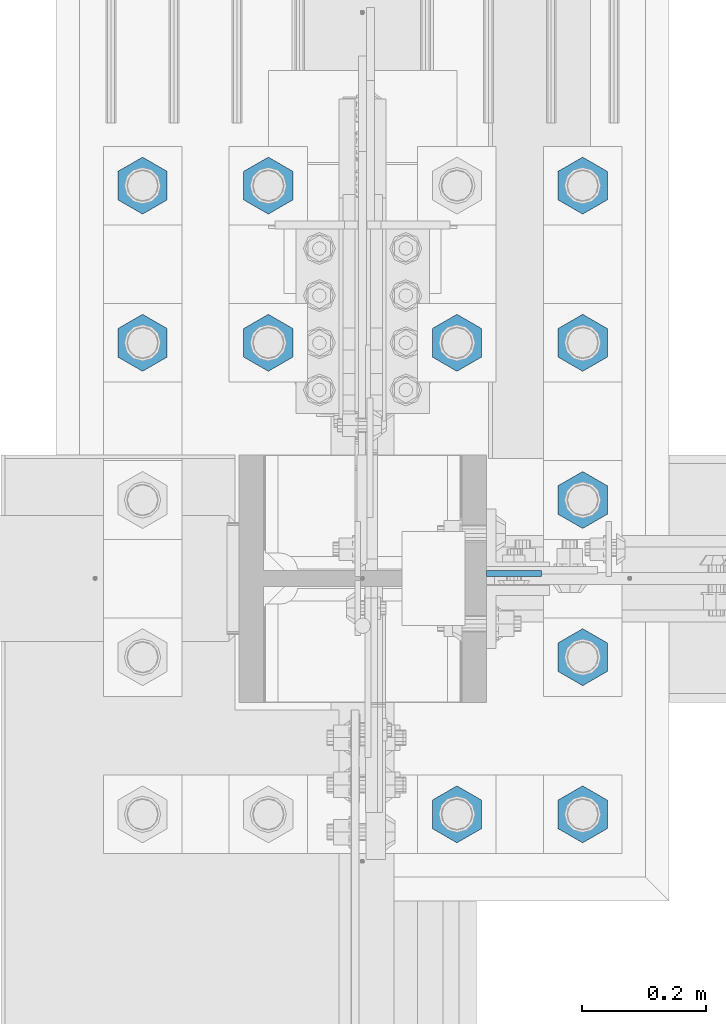
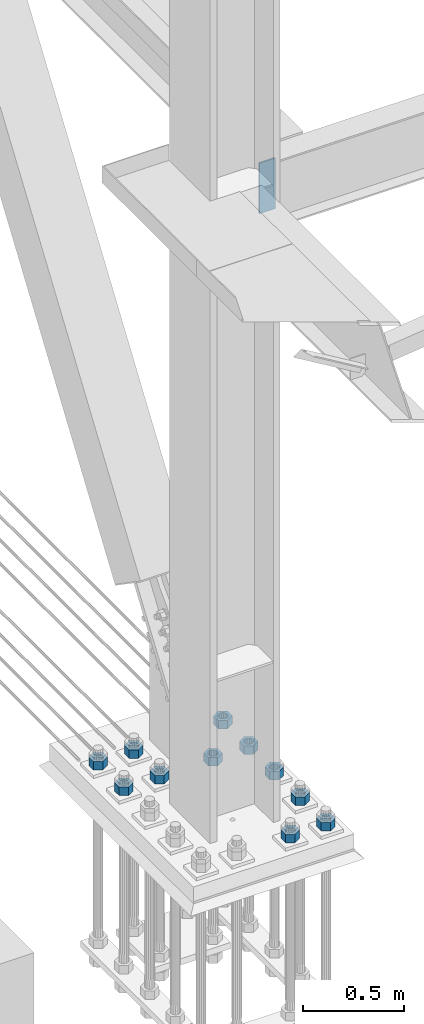
# One storey, part 1520 of 3843: 12 columns, 2 elements without a shape of their own.
"""IFC2X3 building model written with IfcOpenShell, lengths in millimetres."""

from ifc_helpers import new_model, si_unit, frame, origin_with_axes, place, context, subcontext, project, spatial, faceted_brep, material, type_object, element, aggregate, save


model = new_model("IFC2X3")

# Units and contexts
model_context = context("Model", 3, precision=1e-05, world=origin_with_axes())
body_context = subcontext(model_context, "Body", "Model", "MODEL_VIEW")
ifc_project = project(units=[si_unit("LENGTHUNIT", "METRE", prefix="MILLI"), si_unit("AREAUNIT", "SQUARE_METRE"), si_unit("VOLUMEUNIT", "CUBIC_METRE"), si_unit("MASSUNIT", "GRAM", prefix="KILO"), si_unit("TIMEUNIT", "SECOND"), si_unit("PLANEANGLEUNIT", "RADIAN"), si_unit("SOLIDANGLEUNIT", "STERADIAN"), si_unit("THERMODYNAMICTEMPERATUREUNIT", "DEGREE_CELSIUS"), si_unit("LUMINOUSINTENSITYUNIT", "LUMEN")], contexts=[model_context])

# Site, building, storey
site_placement = place(None, origin_with_axes())
site = spatial("IfcSite", under=ifc_project, at=site_placement, CompositionType="ELEMENT")
building_placement = place(site_placement, origin_with_axes())
building = spatial("IfcBuilding", under=site, at=building_placement, Name="Undefined", CompositionType="ELEMENT")
storey_placement = place(building_placement, origin_with_axes())
storey = spatial("IfcBuildingStorey", under=building, at=storey_placement, Name="Undefined", CompositionType="ELEMENT", Elevation=0.0)

# Assembly, column
assembly_1_placement = place(storey_placement, origin_with_axes())
assembly_1 = element("IfcElementAssembly", 1, at=assembly_1_placement, inside=storey, Name="COLUMN", AssemblyPlace="NOTDEFINED", PredefinedType="RIGID_FRAME")
ifc_material = material(Name="STEEL/A572-50")
column_type_1 = type_object("IfcColumnType", PredefinedType="NOTDEFINED")
column_1_placement = place(assembly_1_placement, frame((36820.475, 50566.6375, 33693.0999993376), z_axis=(-1.0, 0.0, 0.0), x_axis=(0.0, 0.0, 1.0)))
column_1 = element("IfcColumn", 2, at=column_1_placement, type_object=column_type_1, material=ifc_material, Name="PLATE", context=body_context, shape_type="Brep", body=[
    faceted_brep([(0.0, 4.76249999999709, -44.4500000000007), (0.0, 4.76249999999709, 44.4500000000007), (304.799999999996, 4.76249999999709, 44.4500000000007), (304.799999999996, 4.76249999999709, -44.4500000000007), (0.0, -4.76249999999709, 44.4500000000007), (304.799999999996, -4.76249999999709, 44.4500000000007), (0.0, -4.76249999999709, -44.4500000000007), (304.799999999996, -4.76249999999709, -44.4500000000007)], [[[0, 1, 2, 3]], [[1, 4, 5, 2]], [[4, 6, 7, 5]], [[6, 0, 3, 7]], [[5, 7, 3, 2]], [[6, 4, 1, 0]]]),
])
aggregate(assembly_1, [column_1])

# Assembly, columns
assembly_2_placement = place(storey_placement, origin_with_axes())
assembly_2 = element("IfcElementAssembly", 3, at=assembly_2_placement, inside=storey, Name="TEMPLATE", AssemblyPlace="NOTDEFINED", PredefinedType="RIGID_FRAME")
column_type_2 = type_object("IfcColumnType", Name="2_HEAVY_HEX_NUT", PredefinedType="NOTDEFINED")
column_2_placement = place(assembly_2_placement, frame((36931.6, 50177.7, 30232.35), z_axis=(1.0, 0.0, 0.0), x_axis=(0.0, 0.0, -1.0)))
column_2 = element("IfcColumn", 4, at=column_2_placement, type_object=column_type_2, material=ifc_material, Name="NUT", ObjectType="2_HEAVY_HEX_NUT", context=body_context, shape_type="Brep", body=[
    faceted_brep([(0.0, -46.0369987487793, 0.0), (0.0, -23.0184993743896, -39.869213104248), (50.7999999999993, -23.0184993743896, -39.869213104248), (50.7999999999993, -46.0369987487793, 0.0), (0.0, 23.0184993743896, -39.869213104248), (50.7999999999993, 23.0184993743896, -39.869213104248), (0.0, 46.0369987487793, 0.0), (50.7999999999993, 46.0369987487793, 0.0), (0.0, 23.0184993743896, 39.869213104248), (50.7999999999993, 23.0184993743896, 39.869213104248), (0.0, -23.0184993743896, 39.869213104248), (50.7999999999993, -23.0184993743896, 39.869213104248), (0.0, 0.0, 26.1940002441406), (0.0, 11.3650617044477, 23.5999013092805), (50.7999999999993, 11.3650617044477, 23.5999013092805), (50.7999999999993, 0.0, 26.1940002441406), (0.0, 20.4791109456419, 16.3316083006721), (50.7999999999993, 20.4791109456419, 16.3316083006721), (0.0, 25.5370200498292, 5.82867859874386), (50.7999999999993, 25.5370200498292, 5.82867859874386), (0.0, 25.5370200498292, -5.82867859874386), (50.7999999999993, 25.5370200498292, -5.82867859874386), (0.0, 20.4791109456419, -16.3316083006721), (50.7999999999993, 20.4791109456419, -16.3316083006721), (0.0, 11.3650617044477, -23.5999013092805), (50.7999999999993, 11.3650617044477, -23.5999013092805), (0.0, 0.0, -26.1940002441406), (50.7999999999993, 0.0, -26.1940002441406), (0.0, -11.3650617044477, -23.5999013092805), (50.7999999999993, -11.3650617044477, -23.5999013092805), (0.0, -20.4791109456419, -16.3316083006721), (50.7999999999993, -20.4791109456419, -16.3316083006721), (0.0, -25.5370200498292, -5.82867859874386), (50.7999999999993, -25.5370200498292, -5.82867859874386), (0.0, -25.5370200498292, 5.82867859874386), (50.7999999999993, -25.5370200498292, 5.82867859874386), (0.0, -20.4791109456419, 16.3316083006721), (50.7999999999993, -20.4791109456419, 16.3316083006721), (0.0, -11.3650617044477, 23.5999013092805), (50.7999999999993, -11.3650617044477, 23.5999013092805)], [[[0, 1, 2, 3]], [[1, 4, 5, 2]], [[4, 6, 7, 5]], [[6, 8, 9, 7]], [[8, 10, 11, 9]], [[10, 0, 3, 11]], [[12, 13, 14, 15]], [[13, 16, 17, 14]], [[16, 18, 19, 17]], [[18, 20, 21, 19]], [[20, 22, 23, 21]], [[22, 24, 25, 23]], [[24, 26, 27, 25]], [[26, 28, 29, 27]], [[28, 30, 31, 29]], [[30, 32, 33, 31]], [[32, 34, 35, 33]], [[34, 36, 37, 35]], [[36, 38, 39, 37]], [[38, 12, 15, 39]], [[5, 7, 9, 11, 3, 2], [17, 19, 21, 23, 25, 27, 29, 31, 33, 35, 37, 39, 15, 14]], [[10, 8, 6, 4, 1, 0], [38, 36, 34, 32, 30, 28, 26, 24, 22, 20, 18, 16, 13, 12]]]),
])
column_3_placement = place(assembly_2_placement, frame((36931.6, 50431.7, 30232.35), z_axis=(1.0, 0.0, 0.0), x_axis=(0.0, 0.0, -1.0)))
column_3 = element("IfcColumn", 5, at=column_3_placement, type_object=column_type_2, material=ifc_material, Name="NUT", ObjectType="2_HEAVY_HEX_NUT", context=body_context, shape_type="Brep", body=[
    faceted_brep([(0.0, -46.0369987487793, 0.0), (0.0, -23.0184993743896, -39.869213104248), (50.7999999999993, -23.0184993743896, -39.869213104248), (50.7999999999993, -46.0369987487793, 0.0), (0.0, 23.0184993743896, -39.869213104248), (50.7999999999993, 23.0184993743896, -39.869213104248), (0.0, 46.0369987487793, 0.0), (50.7999999999993, 46.0369987487793, 0.0), (0.0, 23.0184993743896, 39.869213104248), (50.7999999999993, 23.0184993743896, 39.869213104248), (0.0, -23.0184993743896, 39.869213104248), (50.7999999999993, -23.0184993743896, 39.869213104248), (0.0, 0.0, 26.1940002441406), (0.0, 11.3650617044477, 23.5999013092805), (50.7999999999993, 11.3650617044477, 23.5999013092805), (50.7999999999993, 0.0, 26.1940002441406), (0.0, 20.4791109456419, 16.3316083006721), (50.7999999999993, 20.4791109456419, 16.3316083006721), (0.0, 25.5370200498292, 5.82867859874386), (50.7999999999993, 25.5370200498292, 5.82867859874386), (0.0, 25.5370200498292, -5.82867859874386), (50.7999999999993, 25.5370200498292, -5.82867859874386), (0.0, 20.4791109456419, -16.3316083006721), (50.7999999999993, 20.4791109456419, -16.3316083006721), (0.0, 11.3650617044477, -23.5999013092805), (50.7999999999993, 11.3650617044477, -23.5999013092805), (0.0, 0.0, -26.1940002441406), (50.7999999999993, 0.0, -26.1940002441406), (0.0, -11.3650617044477, -23.5999013092805), (50.7999999999993, -11.3650617044477, -23.5999013092805), (0.0, -20.4791109456419, -16.3316083006721), (50.7999999999993, -20.4791109456419, -16.3316083006721), (0.0, -25.5370200498292, -5.82867859874386), (50.7999999999993, -25.5370200498292, -5.82867859874386), (0.0, -25.5370200498292, 5.82867859874386), (50.7999999999993, -25.5370200498292, 5.82867859874386), (0.0, -20.4791109456419, 16.3316083006721), (50.7999999999993, -20.4791109456419, 16.3316083006721), (0.0, -11.3650617044477, 23.5999013092805), (50.7999999999993, -11.3650617044477, 23.5999013092805)], [[[0, 1, 2, 3]], [[1, 4, 5, 2]], [[4, 6, 7, 5]], [[6, 8, 9, 7]], [[8, 10, 11, 9]], [[10, 0, 3, 11]], [[12, 13, 14, 15]], [[13, 16, 17, 14]], [[16, 18, 19, 17]], [[18, 20, 21, 19]], [[20, 22, 23, 21]], [[22, 24, 25, 23]], [[24, 26, 27, 25]], [[26, 28, 29, 27]], [[28, 30, 31, 29]], [[30, 32, 33, 31]], [[32, 34, 35, 33]], [[34, 36, 37, 35]], [[36, 38, 39, 37]], [[38, 12, 15, 39]], [[5, 7, 9, 11, 3, 2], [17, 19, 21, 23, 25, 27, 29, 31, 33, 35, 37, 39, 15, 14]], [[10, 8, 6, 4, 1, 0], [38, 36, 34, 32, 30, 28, 26, 24, 22, 20, 18, 16, 13, 12]]]),
])
column_4_placement = place(assembly_2_placement, frame((36931.6, 50685.7, 30232.35), z_axis=(1.0, 0.0, 0.0), x_axis=(0.0, 0.0, -1.0)))
column_4 = element("IfcColumn", 6, at=column_4_placement, type_object=column_type_2, material=ifc_material, Name="NUT", ObjectType="2_HEAVY_HEX_NUT", context=body_context, shape_type="Brep", body=[
    faceted_brep([(0.0, -46.0369987487793, 0.0), (0.0, -23.0184993743896, -39.869213104248), (50.7999999999993, -23.0184993743896, -39.869213104248), (50.7999999999993, -46.0369987487793, 0.0), (0.0, 23.0184993743896, -39.869213104248), (50.7999999999993, 23.0184993743896, -39.869213104248), (0.0, 46.0369987487793, 0.0), (50.7999999999993, 46.0369987487793, 0.0), (0.0, 23.0184993743896, 39.869213104248), (50.7999999999993, 23.0184993743896, 39.869213104248), (0.0, -23.0184993743896, 39.869213104248), (50.7999999999993, -23.0184993743896, 39.869213104248), (0.0, 0.0, 26.1940002441406), (0.0, 11.3650617044477, 23.5999013092805), (50.7999999999993, 11.3650617044477, 23.5999013092805), (50.7999999999993, 0.0, 26.1940002441406), (0.0, 20.4791109456419, 16.3316083006721), (50.7999999999993, 20.4791109456419, 16.3316083006721), (0.0, 25.5370200498292, 5.82867859874386), (50.7999999999993, 25.5370200498292, 5.82867859874386), (0.0, 25.5370200498292, -5.82867859874386), (50.7999999999993, 25.5370200498292, -5.82867859874386), (0.0, 20.4791109456419, -16.3316083006721), (50.7999999999993, 20.4791109456419, -16.3316083006721), (0.0, 11.3650617044477, -23.5999013092805), (50.7999999999993, 11.3650617044477, -23.5999013092805), (0.0, 0.0, -26.1940002441406), (50.7999999999993, 0.0, -26.1940002441406), (0.0, -11.3650617044477, -23.5999013092805), (50.7999999999993, -11.3650617044477, -23.5999013092805), (0.0, -20.4791109456419, -16.3316083006721), (50.7999999999993, -20.4791109456419, -16.3316083006721), (0.0, -25.5370200498292, -5.82867859874386), (50.7999999999993, -25.5370200498292, -5.82867859874386), (0.0, -25.5370200498292, 5.82867859874386), (50.7999999999993, -25.5370200498292, 5.82867859874386), (0.0, -20.4791109456419, 16.3316083006721), (50.7999999999993, -20.4791109456419, 16.3316083006721), (0.0, -11.3650617044477, 23.5999013092805), (50.7999999999993, -11.3650617044477, 23.5999013092805)], [[[0, 1, 2, 3]], [[1, 4, 5, 2]], [[4, 6, 7, 5]], [[6, 8, 9, 7]], [[8, 10, 11, 9]], [[10, 0, 3, 11]], [[12, 13, 14, 15]], [[13, 16, 17, 14]], [[16, 18, 19, 17]], [[18, 20, 21, 19]], [[20, 22, 23, 21]], [[22, 24, 25, 23]], [[24, 26, 27, 25]], [[26, 28, 29, 27]], [[28, 30, 31, 29]], [[30, 32, 33, 31]], [[32, 34, 35, 33]], [[34, 36, 37, 35]], [[36, 38, 39, 37]], [[38, 12, 15, 39]], [[5, 7, 9, 11, 3, 2], [17, 19, 21, 23, 25, 27, 29, 31, 33, 35, 37, 39, 15, 14]], [[10, 8, 6, 4, 1, 0], [38, 36, 34, 32, 30, 28, 26, 24, 22, 20, 18, 16, 13, 12]]]),
])
column_5_placement = place(assembly_2_placement, frame((36931.6, 50939.7, 30232.35), z_axis=(-1.0, 0.0, 0.0), x_axis=(0.0, 0.0, -1.0)))
column_5 = element("IfcColumn", 7, at=column_5_placement, type_object=column_type_2, material=ifc_material, Name="NUT", ObjectType="2_HEAVY_HEX_NUT", context=body_context, shape_type="Brep", body=[
    faceted_brep([(0.0, -46.0369987487793, 0.0), (0.0, -23.0184993743896, -39.869213104248), (50.7999999999993, -23.0184993743896, -39.869213104248), (50.7999999999993, -46.0369987487793, 0.0), (0.0, 23.0184993743896, -39.869213104248), (50.7999999999993, 23.0184993743896, -39.869213104248), (0.0, 46.0369987487793, 0.0), (50.7999999999993, 46.0369987487793, 0.0), (0.0, 23.0184993743896, 39.869213104248), (50.7999999999993, 23.0184993743896, 39.869213104248), (0.0, -23.0184993743896, 39.869213104248), (50.7999999999993, -23.0184993743896, 39.869213104248), (0.0, 0.0, 26.1940002441406), (0.0, 11.3650617044477, 23.5999013092805), (50.7999999999993, 11.3650617044477, 23.5999013092805), (50.7999999999993, 0.0, 26.1940002441406), (0.0, 20.4791109456419, 16.3316083006721), (50.7999999999993, 20.4791109456419, 16.3316083006721), (0.0, 25.5370200498292, 5.82867859874386), (50.7999999999993, 25.5370200498292, 5.82867859874386), (0.0, 25.5370200498292, -5.82867859874386), (50.7999999999993, 25.5370200498292, -5.82867859874386), (0.0, 20.4791109456419, -16.3316083006721), (50.7999999999993, 20.4791109456419, -16.3316083006721), (0.0, 11.3650617044477, -23.5999013092805), (50.7999999999993, 11.3650617044477, -23.5999013092805), (0.0, 0.0, -26.1940002441406), (50.7999999999993, 0.0, -26.1940002441406), (0.0, -11.3650617044477, -23.5999013092805), (50.7999999999993, -11.3650617044477, -23.5999013092805), (0.0, -20.4791109456419, -16.3316083006721), (50.7999999999993, -20.4791109456419, -16.3316083006721), (0.0, -25.5370200498292, -5.82867859874386), (50.7999999999993, -25.5370200498292, -5.82867859874386), (0.0, -25.5370200498292, 5.82867859874386), (50.7999999999993, -25.5370200498292, 5.82867859874386), (0.0, -20.4791109456419, 16.3316083006721), (50.7999999999993, -20.4791109456419, 16.3316083006721), (0.0, -11.3650617044477, 23.5999013092805), (50.7999999999993, -11.3650617044477, 23.5999013092805)], [[[0, 1, 2, 3]], [[1, 4, 5, 2]], [[4, 6, 7, 5]], [[6, 8, 9, 7]], [[8, 10, 11, 9]], [[10, 0, 3, 11]], [[12, 13, 14, 15]], [[13, 16, 17, 14]], [[16, 18, 19, 17]], [[18, 20, 21, 19]], [[20, 22, 23, 21]], [[22, 24, 25, 23]], [[24, 26, 27, 25]], [[26, 28, 29, 27]], [[28, 30, 31, 29]], [[30, 32, 33, 31]], [[32, 34, 35, 33]], [[34, 36, 37, 35]], [[36, 38, 39, 37]], [[38, 12, 15, 39]], [[5, 7, 9, 11, 3, 2], [17, 19, 21, 23, 25, 27, 29, 31, 33, 35, 37, 39, 15, 14]], [[10, 8, 6, 4, 1, 0], [38, 36, 34, 32, 30, 28, 26, 24, 22, 20, 18, 16, 13, 12]]]),
])
column_6_placement = place(assembly_2_placement, frame((36931.6, 51193.7, 30232.35), z_axis=(-1.0, 0.0, 0.0), x_axis=(0.0, 0.0, -1.0)))
column_6 = element("IfcColumn", 8, at=column_6_placement, type_object=column_type_2, material=ifc_material, Name="NUT", ObjectType="2_HEAVY_HEX_NUT", context=body_context, shape_type="Brep", body=[
    faceted_brep([(0.0, -46.0369987487793, 0.0), (0.0, -23.0184993743896, -39.869213104248), (50.7999999999993, -23.0184993743896, -39.869213104248), (50.7999999999993, -46.0369987487793, 0.0), (0.0, 23.0184993743896, -39.869213104248), (50.7999999999993, 23.0184993743896, -39.869213104248), (0.0, 46.0369987487793, 0.0), (50.7999999999993, 46.0369987487793, 0.0), (0.0, 23.0184993743896, 39.869213104248), (50.7999999999993, 23.0184993743896, 39.869213104248), (0.0, -23.0184993743896, 39.869213104248), (50.7999999999993, -23.0184993743896, 39.869213104248), (0.0, 0.0, 26.1940002441406), (0.0, 11.3650617044477, 23.5999013092805), (50.7999999999993, 11.3650617044477, 23.5999013092805), (50.7999999999993, 0.0, 26.1940002441406), (0.0, 20.4791109456419, 16.3316083006721), (50.7999999999993, 20.4791109456419, 16.3316083006721), (0.0, 25.5370200498292, 5.82867859874386), (50.7999999999993, 25.5370200498292, 5.82867859874386), (0.0, 25.5370200498292, -5.82867859874386), (50.7999999999993, 25.5370200498292, -5.82867859874386), (0.0, 20.4791109456419, -16.3316083006721), (50.7999999999993, 20.4791109456419, -16.3316083006721), (0.0, 11.3650617044477, -23.5999013092805), (50.7999999999993, 11.3650617044477, -23.5999013092805), (0.0, 0.0, -26.1940002441406), (50.7999999999993, 0.0, -26.1940002441406), (0.0, -11.3650617044477, -23.5999013092805), (50.7999999999993, -11.3650617044477, -23.5999013092805), (0.0, -20.4791109456419, -16.3316083006721), (50.7999999999993, -20.4791109456419, -16.3316083006721), (0.0, -25.5370200498292, -5.82867859874386), (50.7999999999993, -25.5370200498292, -5.82867859874386), (0.0, -25.5370200498292, 5.82867859874386), (50.7999999999993, -25.5370200498292, 5.82867859874386), (0.0, -20.4791109456419, 16.3316083006721), (50.7999999999993, -20.4791109456419, 16.3316083006721), (0.0, -11.3650617044477, 23.5999013092805), (50.7999999999993, -11.3650617044477, 23.5999013092805)], [[[0, 1, 2, 3]], [[1, 4, 5, 2]], [[4, 6, 7, 5]], [[6, 8, 9, 7]], [[8, 10, 11, 9]], [[10, 0, 3, 11]], [[12, 13, 14, 15]], [[13, 16, 17, 14]], [[16, 18, 19, 17]], [[18, 20, 21, 19]], [[20, 22, 23, 21]], [[22, 24, 25, 23]], [[24, 26, 27, 25]], [[26, 28, 29, 27]], [[28, 30, 31, 29]], [[30, 32, 33, 31]], [[32, 34, 35, 33]], [[34, 36, 37, 35]], [[36, 38, 39, 37]], [[38, 12, 15, 39]], [[5, 7, 9, 11, 3, 2], [17, 19, 21, 23, 25, 27, 29, 31, 33, 35, 37, 39, 15, 14]], [[10, 8, 6, 4, 1, 0], [38, 36, 34, 32, 30, 28, 26, 24, 22, 20, 18, 16, 13, 12]]]),
])
column_7_placement = place(assembly_2_placement, frame((36728.4, 50177.7, 30232.35), z_axis=(1.0, 0.0, 0.0), x_axis=(0.0, 0.0, -1.0)))
column_7 = element("IfcColumn", 9, at=column_7_placement, type_object=column_type_2, material=ifc_material, Name="NUT", ObjectType="2_HEAVY_HEX_NUT", context=body_context, shape_type="Brep", body=[
    faceted_brep([(0.0, -46.0369987487793, 0.0), (0.0, -23.0184993743896, -39.869213104248), (50.7999999999993, -23.0184993743896, -39.869213104248), (50.7999999999993, -46.0369987487793, 0.0), (0.0, 23.0184993743896, -39.869213104248), (50.7999999999993, 23.0184993743896, -39.869213104248), (0.0, 46.0369987487793, 0.0), (50.7999999999993, 46.0369987487793, 0.0), (0.0, 23.0184993743896, 39.869213104248), (50.7999999999993, 23.0184993743896, 39.869213104248), (0.0, -23.0184993743896, 39.869213104248), (50.7999999999993, -23.0184993743896, 39.869213104248), (0.0, 0.0, 26.1940002441406), (0.0, 11.3650617044477, 23.5999013092805), (50.7999999999993, 11.3650617044477, 23.5999013092805), (50.7999999999993, 0.0, 26.1940002441406), (0.0, 20.4791109456419, 16.3316083006721), (50.7999999999993, 20.4791109456419, 16.3316083006721), (0.0, 25.5370200498292, 5.82867859874386), (50.7999999999993, 25.5370200498292, 5.82867859874386), (0.0, 25.5370200498292, -5.82867859874386), (50.7999999999993, 25.5370200498292, -5.82867859874386), (0.0, 20.4791109456419, -16.3316083006721), (50.7999999999993, 20.4791109456419, -16.3316083006721), (0.0, 11.3650617044477, -23.5999013092805), (50.7999999999993, 11.3650617044477, -23.5999013092805), (0.0, 0.0, -26.1940002441406), (50.7999999999993, 0.0, -26.1940002441406), (0.0, -11.3650617044477, -23.5999013092805), (50.7999999999993, -11.3650617044477, -23.5999013092805), (0.0, -20.4791109456419, -16.3316083006721), (50.7999999999993, -20.4791109456419, -16.3316083006721), (0.0, -25.5370200498292, -5.82867859874386), (50.7999999999993, -25.5370200498292, -5.82867859874386), (0.0, -25.5370200498292, 5.82867859874386), (50.7999999999993, -25.5370200498292, 5.82867859874386), (0.0, -20.4791109456419, 16.3316083006721), (50.7999999999993, -20.4791109456419, 16.3316083006721), (0.0, -11.3650617044477, 23.5999013092805), (50.7999999999993, -11.3650617044477, 23.5999013092805)], [[[0, 1, 2, 3]], [[1, 4, 5, 2]], [[4, 6, 7, 5]], [[6, 8, 9, 7]], [[8, 10, 11, 9]], [[10, 0, 3, 11]], [[12, 13, 14, 15]], [[13, 16, 17, 14]], [[16, 18, 19, 17]], [[18, 20, 21, 19]], [[20, 22, 23, 21]], [[22, 24, 25, 23]], [[24, 26, 27, 25]], [[26, 28, 29, 27]], [[28, 30, 31, 29]], [[30, 32, 33, 31]], [[32, 34, 35, 33]], [[34, 36, 37, 35]], [[36, 38, 39, 37]], [[38, 12, 15, 39]], [[5, 7, 9, 11, 3, 2], [17, 19, 21, 23, 25, 27, 29, 31, 33, 35, 37, 39, 15, 14]], [[10, 8, 6, 4, 1, 0], [38, 36, 34, 32, 30, 28, 26, 24, 22, 20, 18, 16, 13, 12]]]),
])
column_8_placement = place(assembly_2_placement, frame((36728.4, 50939.7, 30232.35), z_axis=(-1.0, 0.0, 0.0), x_axis=(0.0, 0.0, -1.0)))
column_8 = element("IfcColumn", 10, at=column_8_placement, type_object=column_type_2, material=ifc_material, Name="NUT", ObjectType="2_HEAVY_HEX_NUT", context=body_context, shape_type="Brep", body=[
    faceted_brep([(0.0, -46.0369987487793, 0.0), (0.0, -23.0184993743896, -39.869213104248), (50.7999999999993, -23.0184993743896, -39.869213104248), (50.7999999999993, -46.0369987487793, 0.0), (0.0, 23.0184993743896, -39.869213104248), (50.7999999999993, 23.0184993743896, -39.869213104248), (0.0, 46.0369987487793, 0.0), (50.7999999999993, 46.0369987487793, 0.0), (0.0, 23.0184993743896, 39.869213104248), (50.7999999999993, 23.0184993743896, 39.869213104248), (0.0, -23.0184993743896, 39.869213104248), (50.7999999999993, -23.0184993743896, 39.869213104248), (0.0, 0.0, 26.1940002441406), (0.0, 11.3650617044477, 23.5999013092805), (50.7999999999993, 11.3650617044477, 23.5999013092805), (50.7999999999993, 0.0, 26.1940002441406), (0.0, 20.4791109456419, 16.3316083006721), (50.7999999999993, 20.4791109456419, 16.3316083006721), (0.0, 25.5370200498292, 5.82867859874386), (50.7999999999993, 25.5370200498292, 5.82867859874386), (0.0, 25.5370200498292, -5.82867859874386), (50.7999999999993, 25.5370200498292, -5.82867859874386), (0.0, 20.4791109456419, -16.3316083006721), (50.7999999999993, 20.4791109456419, -16.3316083006721), (0.0, 11.3650617044477, -23.5999013092805), (50.7999999999993, 11.3650617044477, -23.5999013092805), (0.0, 0.0, -26.1940002441406), (50.7999999999993, 0.0, -26.1940002441406), (0.0, -11.3650617044477, -23.5999013092805), (50.7999999999993, -11.3650617044477, -23.5999013092805), (0.0, -20.4791109456419, -16.3316083006721), (50.7999999999993, -20.4791109456419, -16.3316083006721), (0.0, -25.5370200498292, -5.82867859874386), (50.7999999999993, -25.5370200498292, -5.82867859874386), (0.0, -25.5370200498292, 5.82867859874386), (50.7999999999993, -25.5370200498292, 5.82867859874386), (0.0, -20.4791109456419, 16.3316083006721), (50.7999999999993, -20.4791109456419, 16.3316083006721), (0.0, -11.3650617044477, 23.5999013092805), (50.7999999999993, -11.3650617044477, 23.5999013092805)], [[[0, 1, 2, 3]], [[1, 4, 5, 2]], [[4, 6, 7, 5]], [[6, 8, 9, 7]], [[8, 10, 11, 9]], [[10, 0, 3, 11]], [[12, 13, 14, 15]], [[13, 16, 17, 14]], [[16, 18, 19, 17]], [[18, 20, 21, 19]], [[20, 22, 23, 21]], [[22, 24, 25, 23]], [[24, 26, 27, 25]], [[26, 28, 29, 27]], [[28, 30, 31, 29]], [[30, 32, 33, 31]], [[32, 34, 35, 33]], [[34, 36, 37, 35]], [[36, 38, 39, 37]], [[38, 12, 15, 39]], [[5, 7, 9, 11, 3, 2], [17, 19, 21, 23, 25, 27, 29, 31, 33, 35, 37, 39, 15, 14]], [[10, 8, 6, 4, 1, 0], [38, 36, 34, 32, 30, 28, 26, 24, 22, 20, 18, 16, 13, 12]]]),
])
column_9_placement = place(assembly_2_placement, frame((36423.6, 50939.7, 30232.35), z_axis=(-1.0, 0.0, 0.0), x_axis=(0.0, 0.0, -1.0)))
column_9 = element("IfcColumn", 11, at=column_9_placement, type_object=column_type_2, material=ifc_material, Name="NUT", ObjectType="2_HEAVY_HEX_NUT", context=body_context, shape_type="Brep", body=[
    faceted_brep([(0.0, -46.0369987487793, 0.0), (0.0, -23.0184993743896, -39.869213104248), (50.7999999999993, -23.0184993743896, -39.869213104248), (50.7999999999993, -46.0369987487793, 0.0), (0.0, 23.0184993743896, -39.869213104248), (50.7999999999993, 23.0184993743896, -39.869213104248), (0.0, 46.0369987487793, 0.0), (50.7999999999993, 46.0369987487793, 0.0), (0.0, 23.0184993743896, 39.869213104248), (50.7999999999993, 23.0184993743896, 39.869213104248), (0.0, -23.0184993743896, 39.869213104248), (50.7999999999993, -23.0184993743896, 39.869213104248), (0.0, 0.0, 26.1940002441406), (0.0, 11.3650617044477, 23.5999013092805), (50.7999999999993, 11.3650617044477, 23.5999013092805), (50.7999999999993, 0.0, 26.1940002441406), (0.0, 20.4791109456419, 16.3316083006721), (50.7999999999993, 20.4791109456419, 16.3316083006721), (0.0, 25.5370200498292, 5.82867859874386), (50.7999999999993, 25.5370200498292, 5.82867859874386), (0.0, 25.5370200498292, -5.82867859874386), (50.7999999999993, 25.5370200498292, -5.82867859874386), (0.0, 20.4791109456419, -16.3316083006721), (50.7999999999993, 20.4791109456419, -16.3316083006721), (0.0, 11.3650617044477, -23.5999013092805), (50.7999999999993, 11.3650617044477, -23.5999013092805), (0.0, 0.0, -26.1940002441406), (50.7999999999993, 0.0, -26.1940002441406), (0.0, -11.3650617044477, -23.5999013092805), (50.7999999999993, -11.3650617044477, -23.5999013092805), (0.0, -20.4791109456419, -16.3316083006721), (50.7999999999993, -20.4791109456419, -16.3316083006721), (0.0, -25.5370200498292, -5.82867859874386), (50.7999999999993, -25.5370200498292, -5.82867859874386), (0.0, -25.5370200498292, 5.82867859874386), (50.7999999999993, -25.5370200498292, 5.82867859874386), (0.0, -20.4791109456419, 16.3316083006721), (50.7999999999993, -20.4791109456419, 16.3316083006721), (0.0, -11.3650617044477, 23.5999013092805), (50.7999999999993, -11.3650617044477, 23.5999013092805)], [[[0, 1, 2, 3]], [[1, 4, 5, 2]], [[4, 6, 7, 5]], [[6, 8, 9, 7]], [[8, 10, 11, 9]], [[10, 0, 3, 11]], [[12, 13, 14, 15]], [[13, 16, 17, 14]], [[16, 18, 19, 17]], [[18, 20, 21, 19]], [[20, 22, 23, 21]], [[22, 24, 25, 23]], [[24, 26, 27, 25]], [[26, 28, 29, 27]], [[28, 30, 31, 29]], [[30, 32, 33, 31]], [[32, 34, 35, 33]], [[34, 36, 37, 35]], [[36, 38, 39, 37]], [[38, 12, 15, 39]], [[5, 7, 9, 11, 3, 2], [17, 19, 21, 23, 25, 27, 29, 31, 33, 35, 37, 39, 15, 14]], [[10, 8, 6, 4, 1, 0], [38, 36, 34, 32, 30, 28, 26, 24, 22, 20, 18, 16, 13, 12]]]),
])
column_10_placement = place(assembly_2_placement, frame((36423.6, 51193.7, 30232.35), z_axis=(-1.0, 0.0, 0.0), x_axis=(0.0, 0.0, -1.0)))
column_10 = element("IfcColumn", 12, at=column_10_placement, type_object=column_type_2, material=ifc_material, Name="NUT", ObjectType="2_HEAVY_HEX_NUT", context=body_context, shape_type="Brep", body=[
    faceted_brep([(0.0, -46.0369987487793, 0.0), (0.0, -23.0184993743896, -39.869213104248), (50.7999999999993, -23.0184993743896, -39.869213104248), (50.7999999999993, -46.0369987487793, 0.0), (0.0, 23.0184993743896, -39.869213104248), (50.7999999999993, 23.0184993743896, -39.869213104248), (0.0, 46.0369987487793, 0.0), (50.7999999999993, 46.0369987487793, 0.0), (0.0, 23.0184993743896, 39.869213104248), (50.7999999999993, 23.0184993743896, 39.869213104248), (0.0, -23.0184993743896, 39.869213104248), (50.7999999999993, -23.0184993743896, 39.869213104248), (0.0, 0.0, 26.1940002441406), (0.0, 11.3650617044477, 23.5999013092805), (50.7999999999993, 11.3650617044477, 23.5999013092805), (50.7999999999993, 0.0, 26.1940002441406), (0.0, 20.4791109456419, 16.3316083006721), (50.7999999999993, 20.4791109456419, 16.3316083006721), (0.0, 25.5370200498292, 5.82867859874386), (50.7999999999993, 25.5370200498292, 5.82867859874386), (0.0, 25.5370200498292, -5.82867859874386), (50.7999999999993, 25.5370200498292, -5.82867859874386), (0.0, 20.4791109456419, -16.3316083006721), (50.7999999999993, 20.4791109456419, -16.3316083006721), (0.0, 11.3650617044477, -23.5999013092805), (50.7999999999993, 11.3650617044477, -23.5999013092805), (0.0, 0.0, -26.1940002441406), (50.7999999999993, 0.0, -26.1940002441406), (0.0, -11.3650617044477, -23.5999013092805), (50.7999999999993, -11.3650617044477, -23.5999013092805), (0.0, -20.4791109456419, -16.3316083006721), (50.7999999999993, -20.4791109456419, -16.3316083006721), (0.0, -25.5370200498292, -5.82867859874386), (50.7999999999993, -25.5370200498292, -5.82867859874386), (0.0, -25.5370200498292, 5.82867859874386), (50.7999999999993, -25.5370200498292, 5.82867859874386), (0.0, -20.4791109456419, 16.3316083006721), (50.7999999999993, -20.4791109456419, 16.3316083006721), (0.0, -11.3650617044477, 23.5999013092805), (50.7999999999993, -11.3650617044477, 23.5999013092805)], [[[0, 1, 2, 3]], [[1, 4, 5, 2]], [[4, 6, 7, 5]], [[6, 8, 9, 7]], [[8, 10, 11, 9]], [[10, 0, 3, 11]], [[12, 13, 14, 15]], [[13, 16, 17, 14]], [[16, 18, 19, 17]], [[18, 20, 21, 19]], [[20, 22, 23, 21]], [[22, 24, 25, 23]], [[24, 26, 27, 25]], [[26, 28, 29, 27]], [[28, 30, 31, 29]], [[30, 32, 33, 31]], [[32, 34, 35, 33]], [[34, 36, 37, 35]], [[36, 38, 39, 37]], [[38, 12, 15, 39]], [[5, 7, 9, 11, 3, 2], [17, 19, 21, 23, 25, 27, 29, 31, 33, 35, 37, 39, 15, 14]], [[10, 8, 6, 4, 1, 0], [38, 36, 34, 32, 30, 28, 26, 24, 22, 20, 18, 16, 13, 12]]]),
])
column_11_placement = place(assembly_2_placement, frame((36220.4, 50939.7, 30232.35), z_axis=(-1.0, 0.0, 0.0), x_axis=(0.0, 0.0, -1.0)))
column_11 = element("IfcColumn", 13, at=column_11_placement, type_object=column_type_2, material=ifc_material, Name="NUT", ObjectType="2_HEAVY_HEX_NUT", context=body_context, shape_type="Brep", body=[
    faceted_brep([(0.0, -46.0369987487793, 0.0), (0.0, -23.0184993743896, -39.869213104248), (50.7999999999993, -23.0184993743896, -39.869213104248), (50.7999999999993, -46.0369987487793, 0.0), (0.0, 23.0184993743896, -39.869213104248), (50.7999999999993, 23.0184993743896, -39.869213104248), (0.0, 46.0369987487793, 0.0), (50.7999999999993, 46.0369987487793, 0.0), (0.0, 23.0184993743896, 39.869213104248), (50.7999999999993, 23.0184993743896, 39.869213104248), (0.0, -23.0184993743896, 39.869213104248), (50.7999999999993, -23.0184993743896, 39.869213104248), (0.0, 0.0, 26.1940002441406), (0.0, 11.3650617044477, 23.5999013092805), (50.7999999999993, 11.3650617044477, 23.5999013092805), (50.7999999999993, 0.0, 26.1940002441406), (0.0, 20.4791109456419, 16.3316083006721), (50.7999999999993, 20.4791109456419, 16.3316083006721), (0.0, 25.5370200498292, 5.82867859874386), (50.7999999999993, 25.5370200498292, 5.82867859874386), (0.0, 25.5370200498292, -5.82867859874386), (50.7999999999993, 25.5370200498292, -5.82867859874386), (0.0, 20.4791109456419, -16.3316083006721), (50.7999999999993, 20.4791109456419, -16.3316083006721), (0.0, 11.3650617044477, -23.5999013092805), (50.7999999999993, 11.3650617044477, -23.5999013092805), (0.0, 0.0, -26.1940002441406), (50.7999999999993, 0.0, -26.1940002441406), (0.0, -11.3650617044477, -23.5999013092805), (50.7999999999993, -11.3650617044477, -23.5999013092805), (0.0, -20.4791109456419, -16.3316083006721), (50.7999999999993, -20.4791109456419, -16.3316083006721), (0.0, -25.5370200498292, -5.82867859874386), (50.7999999999993, -25.5370200498292, -5.82867859874386), (0.0, -25.5370200498292, 5.82867859874386), (50.7999999999993, -25.5370200498292, 5.82867859874386), (0.0, -20.4791109456419, 16.3316083006721), (50.7999999999993, -20.4791109456419, 16.3316083006721), (0.0, -11.3650617044477, 23.5999013092805), (50.7999999999993, -11.3650617044477, 23.5999013092805)], [[[0, 1, 2, 3]], [[1, 4, 5, 2]], [[4, 6, 7, 5]], [[6, 8, 9, 7]], [[8, 10, 11, 9]], [[10, 0, 3, 11]], [[12, 13, 14, 15]], [[13, 16, 17, 14]], [[16, 18, 19, 17]], [[18, 20, 21, 19]], [[20, 22, 23, 21]], [[22, 24, 25, 23]], [[24, 26, 27, 25]], [[26, 28, 29, 27]], [[28, 30, 31, 29]], [[30, 32, 33, 31]], [[32, 34, 35, 33]], [[34, 36, 37, 35]], [[36, 38, 39, 37]], [[38, 12, 15, 39]], [[5, 7, 9, 11, 3, 2], [17, 19, 21, 23, 25, 27, 29, 31, 33, 35, 37, 39, 15, 14]], [[10, 8, 6, 4, 1, 0], [38, 36, 34, 32, 30, 28, 26, 24, 22, 20, 18, 16, 13, 12]]]),
])
column_12_placement = place(assembly_2_placement, frame((36220.4, 51193.7, 30232.35), z_axis=(-1.0, 0.0, 0.0), x_axis=(0.0, 0.0, -1.0)))
column_12 = element("IfcColumn", 14, at=column_12_placement, type_object=column_type_2, material=ifc_material, Name="NUT", ObjectType="2_HEAVY_HEX_NUT", context=body_context, shape_type="Brep", body=[
    faceted_brep([(0.0, -46.0369987487793, 0.0), (0.0, -23.0184993743896, -39.869213104248), (50.7999999999993, -23.0184993743896, -39.869213104248), (50.7999999999993, -46.0369987487793, 0.0), (0.0, 23.0184993743896, -39.869213104248), (50.7999999999993, 23.0184993743896, -39.869213104248), (0.0, 46.0369987487793, 0.0), (50.7999999999993, 46.0369987487793, 0.0), (0.0, 23.0184993743896, 39.869213104248), (50.7999999999993, 23.0184993743896, 39.869213104248), (0.0, -23.0184993743896, 39.869213104248), (50.7999999999993, -23.0184993743896, 39.869213104248), (0.0, 0.0, 26.1940002441406), (0.0, 11.3650617044477, 23.5999013092805), (50.7999999999993, 11.3650617044477, 23.5999013092805), (50.7999999999993, 0.0, 26.1940002441406), (0.0, 20.4791109456419, 16.3316083006721), (50.7999999999993, 20.4791109456419, 16.3316083006721), (0.0, 25.5370200498292, 5.82867859874386), (50.7999999999993, 25.5370200498292, 5.82867859874386), (0.0, 25.5370200498292, -5.82867859874386), (50.7999999999993, 25.5370200498292, -5.82867859874386), (0.0, 20.4791109456419, -16.3316083006721), (50.7999999999993, 20.4791109456419, -16.3316083006721), (0.0, 11.3650617044477, -23.5999013092805), (50.7999999999993, 11.3650617044477, -23.5999013092805), (0.0, 0.0, -26.1940002441406), (50.7999999999993, 0.0, -26.1940002441406), (0.0, -11.3650617044477, -23.5999013092805), (50.7999999999993, -11.3650617044477, -23.5999013092805), (0.0, -20.4791109456419, -16.3316083006721), (50.7999999999993, -20.4791109456419, -16.3316083006721), (0.0, -25.5370200498292, -5.82867859874386), (50.7999999999993, -25.5370200498292, -5.82867859874386), (0.0, -25.5370200498292, 5.82867859874386), (50.7999999999993, -25.5370200498292, 5.82867859874386), (0.0, -20.4791109456419, 16.3316083006721), (50.7999999999993, -20.4791109456419, 16.3316083006721), (0.0, -11.3650617044477, 23.5999013092805), (50.7999999999993, -11.3650617044477, 23.5999013092805)], [[[0, 1, 2, 3]], [[1, 4, 5, 2]], [[4, 6, 7, 5]], [[6, 8, 9, 7]], [[8, 10, 11, 9]], [[10, 0, 3, 11]], [[12, 13, 14, 15]], [[13, 16, 17, 14]], [[16, 18, 19, 17]], [[18, 20, 21, 19]], [[20, 22, 23, 21]], [[22, 24, 25, 23]], [[24, 26, 27, 25]], [[26, 28, 29, 27]], [[28, 30, 31, 29]], [[30, 32, 33, 31]], [[32, 34, 35, 33]], [[34, 36, 37, 35]], [[36, 38, 39, 37]], [[38, 12, 15, 39]], [[5, 7, 9, 11, 3, 2], [17, 19, 21, 23, 25, 27, 29, 31, 33, 35, 37, 39, 15, 14]], [[10, 8, 6, 4, 1, 0], [38, 36, 34, 32, 30, 28, 26, 24, 22, 20, 18, 16, 13, 12]]]),
])
aggregate(assembly_2, [column_2, column_3, column_4, column_5, column_6, column_7, column_8, column_9, column_10, column_11, column_12])

save(model, "model.ifc")
